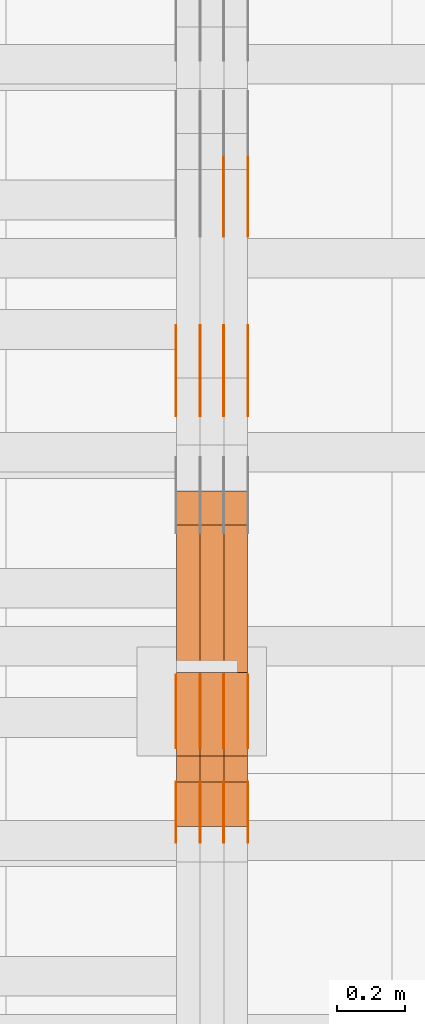
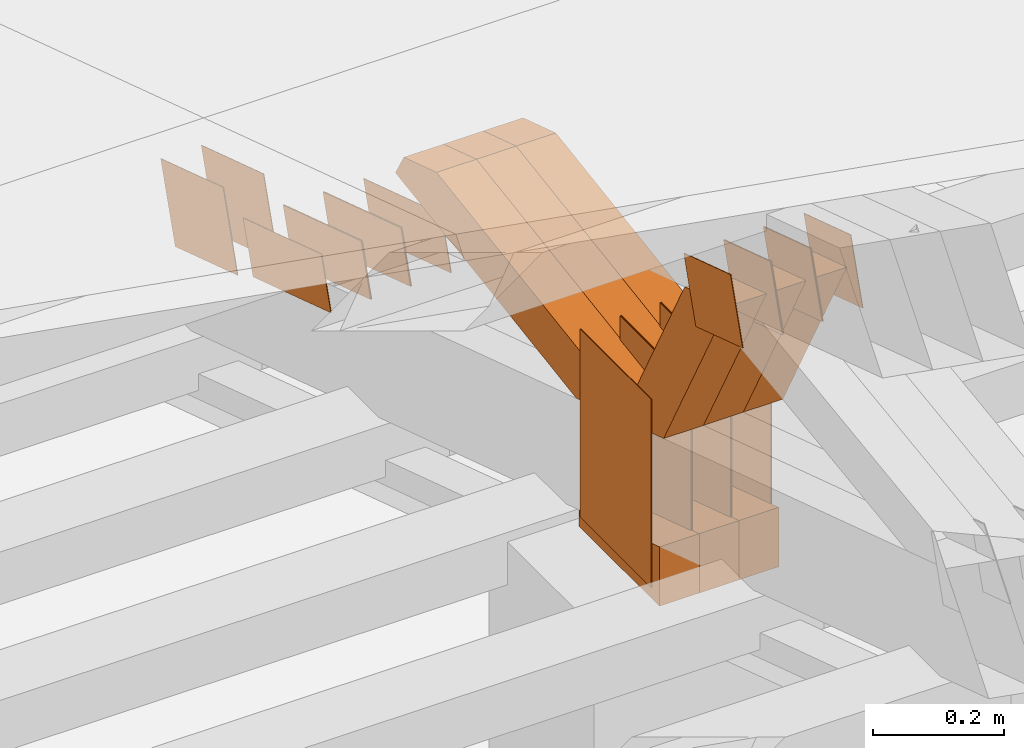
# One storey, part 86 of 385: 29 proxies.
"""IFC2X3 building model written with IfcOpenShell, lengths in millimetres."""

from ifc_helpers import new_model, entity, si_unit, converted_unit, derived_unit, direction, frame, origin, origin_2d_with_axis, place, context, subcontext, project, spatial, polyline, rectangle, outline, extrude, source, transform, mapped, material, type_object, type_shapes, element, save


model = new_model("IFC2X3")

# Units and contexts
model_context = context("Model", 3, precision=0.01, world=origin(), true_north=direction((6.12303176911189e-17, 1.0)))
body_context = subcontext(model_context, "Body", "Model", "MODEL_VIEW")
ifc_project = project(units=[si_unit("LENGTHUNIT", "METRE", prefix="MILLI"), si_unit("AREAUNIT", "SQUARE_METRE"), si_unit("VOLUMEUNIT", "CUBIC_METRE"), converted_unit("PLANEANGLEUNIT", "DEGREE", entity("IfcRatioMeasure", 0.0174532925199433), si_unit("PLANEANGLEUNIT", "RADIAN"), dimensions=[0, 0, 0, 0, 0, 0, 0]), si_unit("MASSUNIT", "GRAM", prefix="KILO"), derived_unit("MASSDENSITYUNIT", [(si_unit("MASSUNIT", "GRAM", prefix="KILO"), 1), (si_unit("LENGTHUNIT", "METRE"), -3)]), si_unit("TIMEUNIT", "SECOND"), si_unit("FREQUENCYUNIT", "HERTZ"), si_unit("THERMODYNAMICTEMPERATUREUNIT", "DEGREE_CELSIUS"), derived_unit("THERMALTRANSMITTANCEUNIT", [(si_unit("MASSUNIT", "GRAM", prefix="KILO"), 1), (si_unit("THERMODYNAMICTEMPERATUREUNIT", "KELVIN"), -1), (si_unit("TIMEUNIT", "SECOND"), -3)]), derived_unit("VOLUMETRICFLOWRATEUNIT", [(si_unit("LENGTHUNIT", "METRE"), 3), (si_unit("TIMEUNIT", "SECOND"), -1)]), si_unit("ELECTRICCURRENTUNIT", "AMPERE"), si_unit("ELECTRICVOLTAGEUNIT", "VOLT"), si_unit("POWERUNIT", "WATT"), si_unit("FORCEUNIT", "NEWTON", prefix="KILO"), si_unit("ILLUMINANCEUNIT", "LUX"), si_unit("LUMINOUSFLUXUNIT", "LUMEN"), si_unit("LUMINOUSINTENSITYUNIT", "CANDELA"), derived_unit("USERDEFINED", [(si_unit("MASSUNIT", "GRAM", prefix="KILO"), -1), (si_unit("LENGTHUNIT", "METRE"), -2), (si_unit("TIMEUNIT", "SECOND"), 3), (si_unit("LUMINOUSFLUXUNIT", "LUMEN"), 1)]), derived_unit("LINEARVELOCITYUNIT", [(si_unit("LENGTHUNIT", "METRE"), 1), (si_unit("TIMEUNIT", "SECOND"), -1)]), si_unit("PRESSUREUNIT", "PASCAL"), derived_unit("USERDEFINED", [(si_unit("LENGTHUNIT", "METRE"), -2), (si_unit("MASSUNIT", "GRAM", prefix="KILO"), 1), (si_unit("TIMEUNIT", "SECOND"), -2)])], contexts=[model_context])

# Site, building, storey
site_placement = place(None, origin())
site = spatial("IfcSite", under=ifc_project, at=site_placement, CompositionType="ELEMENT")
building_placement = place(site_placement, origin())
building = spatial("IfcBuilding", under=site, at=building_placement, CompositionType="ELEMENT")
storey_placement = place(building_placement, origin())
storey = spatial("IfcBuildingStorey", under=building, at=storey_placement, Name="Default", CompositionType="ELEMENT", Elevation=0.0)

# Proxies
ifc_material_1 = material(Name="IfcSurfaceStyle #66966")
building_element_proxy_type_1 = type_object("IfcBuildingElementProxyType", PredefinedType="NOTDEFINED", material=ifc_material_1)
shared_shape_1 = source(origin(), body_context, "Body", "SweptSolid", [
    extrude(outline(polyline([(-125.00031378339, -47.9999612158856), (125.000225258022, -47.9999612158856), (124.999811678525, 47.9999612158856), (-124.999723153156, 47.9999612158856), (-125.00031378339, -47.9999612158856)])), frame((125.000225258022, 48.0000091013474, 0.0), z_axis=(0.0, 0.0, 1.0), x_axis=(-1.0, 0.0, 0.0)), (0.0, 0.0, 1.0), 1.3),
])
type_shapes(building_element_proxy_type_1, [shared_shape_1])
proxy_1_placement = place(building_placement, frame((3386.29999999999, 18456.8597683375, 2657.46691321253), z_axis=(-1.0, 0.0, 0.0), x_axis=(0.0, -0.951056516295124, 0.309016994375039)))
element("IfcBuildingElementProxy", 1, at=proxy_1_placement, inside=storey, type_object=building_element_proxy_type_1, material=ifc_material_1, context=body_context, shape_type="MappedRepresentation", body=[
    mapped(shared_shape_1, transform((0.0, 0.0, 0.0), scale=1.0)),
])
ifc_material_2 = material(Name="IfcSurfaceStyle #66909")
building_element_proxy_type_2 = type_object("IfcBuildingElementProxyType", PredefinedType="NOTDEFINED", material=ifc_material_2)
shared_shape_2 = source(origin(), body_context, "Body", "SweptSolid", [
    extrude(outline(polyline([(-125.00031378339, -47.9999612158856), (125.000225258022, -47.9999612158856), (124.999811678525, 47.9999612158856), (-124.999723153156, 47.9999612158856), (-125.00031378339, -47.9999612158856)])), frame((125.000225258022, 48.0000091013474, 0.0), z_axis=(0.0, 0.0, 1.0), x_axis=(-1.0, 0.0, 0.0)), (0.0, 0.0, 1.0), 1.3),
])
type_shapes(building_element_proxy_type_2, [shared_shape_2])
proxy_2_placement = place(building_placement, frame((3315.0, 18456.8597683375, 2657.46691321253), z_axis=(-1.0, 0.0, 0.0), x_axis=(0.0, -0.951056516295124, 0.309016994375039)))
element("IfcBuildingElementProxy", 2, at=proxy_2_placement, inside=storey, type_object=building_element_proxy_type_2, material=ifc_material_2, context=body_context, shape_type="MappedRepresentation", body=[
    mapped(shared_shape_2, transform((0.0, 0.0, 0.0), scale=1.0)),
])
ifc_material_3 = material(Name="IfcSurfaceStyle #66852")
building_element_proxy_type_3 = type_object("IfcBuildingElementProxyType", PredefinedType="NOTDEFINED", material=ifc_material_3)
shared_shape_3 = source(origin(), body_context, "Body", "SweptSolid", [
    extrude(outline(polyline([(-125.00031378339, -47.9999612158856), (125.000225258022, -47.9999612158856), (124.999811678525, 47.9999612158856), (-124.999723153156, 47.9999612158856), (-125.00031378339, -47.9999612158856)])), frame((125.000225258022, 48.0000091013474, 0.0), z_axis=(0.0, 0.0, 1.0), x_axis=(-1.0, 0.0, 0.0)), (0.0, 0.0, 1.0), 1.3),
])
type_shapes(building_element_proxy_type_3, [shared_shape_3])
proxy_3_placement = place(building_placement, frame((3316.29999999999, 18456.8597683375, 2657.46691321253), z_axis=(-1.0, 0.0, 0.0), x_axis=(0.0, -0.951056516295124, 0.309016994375039)))
element("IfcBuildingElementProxy", 3, at=proxy_3_placement, inside=storey, type_object=building_element_proxy_type_3, material=ifc_material_3, context=body_context, shape_type="MappedRepresentation", body=[
    mapped(shared_shape_3, transform((0.0, 0.0, 0.0), scale=1.0)),
])
ifc_material_4 = material(Name="IfcSurfaceStyle #66795")
building_element_proxy_type_4 = type_object("IfcBuildingElementProxyType", PredefinedType="NOTDEFINED", material=ifc_material_4)
shared_shape_4 = source(origin(), body_context, "Body", "SweptSolid", [
    extrude(outline(polyline([(-125.00031378339, -47.9999612158856), (125.000225258022, -47.9999612158856), (124.999811678525, 47.9999612158856), (-124.999723153156, 47.9999612158856), (-125.00031378339, -47.9999612158856)])), frame((125.000225258022, 48.0000091013474, 0.0), z_axis=(0.0, 0.0, 1.0), x_axis=(-1.0, 0.0, 0.0)), (0.0, 0.0, 1.0), 1.29999999999998),
])
type_shapes(building_element_proxy_type_4, [shared_shape_4])
proxy_4_placement = place(building_placement, frame((3245.0, 18456.8597683375, 2657.46691321253), z_axis=(-1.0, 0.0, 0.0), x_axis=(0.0, -0.951056516295124, 0.309016994375039)))
element("IfcBuildingElementProxy", 4, at=proxy_4_placement, inside=storey, type_object=building_element_proxy_type_4, material=ifc_material_4, context=body_context, shape_type="MappedRepresentation", body=[
    mapped(shared_shape_4, transform((0.0, 0.0, 0.0), scale=1.0)),
])
ifc_material_5 = material(Name="IfcSurfaceStyle #66738")
building_element_proxy_type_5 = type_object("IfcBuildingElementProxyType", PredefinedType="NOTDEFINED", material=ifc_material_5)
shared_shape_5 = source(origin(), body_context, "Body", "SweptSolid", [
    extrude(outline(polyline([(-125.00031378339, -47.9999612158856), (125.000225258022, -47.9999612158856), (124.999811678525, 47.9999612158856), (-124.999723153156, 47.9999612158856), (-125.00031378339, -47.9999612158856)])), frame((125.000225258022, 48.0000091013474, 0.0), z_axis=(0.0, 0.0, 1.0), x_axis=(-1.0, 0.0, 0.0)), (0.0, 0.0, 1.0), 1.29999999999998),
])
type_shapes(building_element_proxy_type_5, [shared_shape_5])
proxy_5_placement = place(building_placement, frame((3246.29999999999, 18456.8597683375, 2657.46691321253), z_axis=(-1.0, 0.0, 0.0), x_axis=(0.0, -0.951056516295124, 0.309016994375039)))
element("IfcBuildingElementProxy", 5, at=proxy_5_placement, inside=storey, type_object=building_element_proxy_type_5, material=ifc_material_5, context=body_context, shape_type="MappedRepresentation", body=[
    mapped(shared_shape_5, transform((0.0, 0.0, 0.0), scale=1.0)),
])
ifc_material_6 = material(Name="IfcSurfaceStyle #66681")
building_element_proxy_type_6 = type_object("IfcBuildingElementProxyType", PredefinedType="NOTDEFINED", material=ifc_material_6)
shared_shape_6 = source(origin(), body_context, "Body", "SweptSolid", [
    extrude(outline(polyline([(-125.00031378339, -47.9999612158856), (125.000225258022, -47.9999612158856), (124.999811678525, 47.9999612158856), (-124.999723153156, 47.9999612158856), (-125.00031378339, -47.9999612158856)])), frame((125.000225258022, 48.0000091013474, 0.0), z_axis=(0.0, 0.0, 1.0), x_axis=(-1.0, 0.0, 0.0)), (0.0, 0.0, 1.0), 1.29999999999998),
])
type_shapes(building_element_proxy_type_6, [shared_shape_6])
proxy_6_placement = place(building_placement, frame((3175.0, 18456.8597683375, 2657.46691321253), z_axis=(-1.0, 0.0, 0.0), x_axis=(0.0, -0.951056516295124, 0.309016994375039)))
element("IfcBuildingElementProxy", 6, at=proxy_6_placement, inside=storey, type_object=building_element_proxy_type_6, material=ifc_material_6, context=body_context, shape_type="MappedRepresentation", body=[
    mapped(shared_shape_6, transform((0.0, 0.0, 0.0), scale=1.0)),
])
ifc_material_7 = material(Name="IfcSurfaceStyle #65256")
building_element_proxy_type_7 = type_object("IfcBuildingElementProxyType", PredefinedType="NOTDEFINED", material=ifc_material_7)
shared_shape_7 = source(origin(), body_context, "Body", "SweptSolid", [
    extrude(outline(polyline([(-99.999796294464, -72.0000050220467), (99.9998768370438, -72.0000050220467), (100.000260677528, 72.0000050220467), (-100.000341220108, 72.0000050220467), (-99.999796294464, -72.0000050220467)])), frame((100.000260677528, 72.0000050220467, 0.0), z_axis=(0.0, 0.0, 1.0), x_axis=(-1.0, 0.0, 0.0)), (0.0, 0.0, 1.0), 1.3),
])
type_shapes(building_element_proxy_type_7, [shared_shape_7])
proxy_7_placement = place(building_placement, frame((3386.29999999999, 18936.3876569477, 2373.90613192527), z_axis=(-1.0, 0.0, 0.0), x_axis=(0.0, -0.951056516295124, 0.309016994375039)))
element("IfcBuildingElementProxy", 7, at=proxy_7_placement, inside=storey, type_object=building_element_proxy_type_7, material=ifc_material_7, context=body_context, shape_type="MappedRepresentation", body=[
    mapped(shared_shape_7, transform((0.0, 0.0, 0.0), scale=1.0)),
])
ifc_material_8 = material(Name="IfcSurfaceStyle #65199")
building_element_proxy_type_8 = type_object("IfcBuildingElementProxyType", PredefinedType="NOTDEFINED", material=ifc_material_8)
shared_shape_8 = source(origin(), body_context, "Body", "SweptSolid", [
    extrude(outline(polyline([(-99.999796294464, -72.0000050220467), (99.9998768370438, -72.0000050220467), (100.000260677528, 72.0000050220467), (-100.000341220108, 72.0000050220467), (-99.999796294464, -72.0000050220467)])), frame((100.000260677528, 72.0000050220467, 0.0), z_axis=(0.0, 0.0, 1.0), x_axis=(-1.0, 0.0, 0.0)), (0.0, 0.0, 1.0), 1.3),
])
type_shapes(building_element_proxy_type_8, [shared_shape_8])
proxy_8_placement = place(building_placement, frame((3315.0, 18936.3876569477, 2373.90613192527), z_axis=(-1.0, 0.0, 0.0), x_axis=(0.0, -0.951056516295124, 0.309016994375039)))
element("IfcBuildingElementProxy", 8, at=proxy_8_placement, inside=storey, type_object=building_element_proxy_type_8, material=ifc_material_8, context=body_context, shape_type="MappedRepresentation", body=[
    mapped(shared_shape_8, transform((0.0, 0.0, 0.0), scale=1.0)),
])
ifc_material_9 = material(Name="IfcSurfaceStyle #64914")
building_element_proxy_type_9 = type_object("IfcBuildingElementProxyType", PredefinedType="NOTDEFINED", material=ifc_material_9)
shared_shape_9 = source(origin(), body_context, "Body", "SweptSolid", [
    extrude(rectangle(XDim=350.0, YDim=215.999999999984, at=origin_2d_with_axis()), frame((175.0, 108.0, 0.0), z_axis=(0.0, 0.0, 1.0), x_axis=(-1.0, 0.0, 0.0)), (0.0, 0.0, 1.0), 1.29999999999999),
])
type_shapes(building_element_proxy_type_9, [shared_shape_9])
proxy_9_placement = place(building_placement, frame((3386.29999999999, 17459.2939453125, 3165.36425781251), z_axis=(-1.0, 0.0, 0.0), x_axis=(0.0, 0.0, -1.0)))
element("IfcBuildingElementProxy", 9, at=proxy_9_placement, inside=storey, type_object=building_element_proxy_type_9, material=ifc_material_9, context=body_context, shape_type="MappedRepresentation", body=[
    mapped(shared_shape_9, transform((0.0, 0.0, 0.0), scale=1.0)),
])
ifc_material_10 = material(Name="IfcSurfaceStyle #64857")
building_element_proxy_type_10 = type_object("IfcBuildingElementProxyType", PredefinedType="NOTDEFINED", material=ifc_material_10)
shared_shape_10 = source(origin(), body_context, "Body", "SweptSolid", [
    extrude(rectangle(XDim=350.0, YDim=215.999999999984, at=origin_2d_with_axis()), frame((175.0, 108.0, 0.0), z_axis=(0.0, 0.0, 1.0), x_axis=(-1.0, 0.0, 0.0)), (0.0, 0.0, 1.0), 1.29999999999999),
])
type_shapes(building_element_proxy_type_10, [shared_shape_10])
proxy_10_placement = place(building_placement, frame((3315.0, 17459.2939453125, 3165.36425781251), z_axis=(-1.0, 0.0, 0.0), x_axis=(0.0, 0.0, -1.0)))
element("IfcBuildingElementProxy", 10, at=proxy_10_placement, inside=storey, type_object=building_element_proxy_type_10, material=ifc_material_10, context=body_context, shape_type="MappedRepresentation", body=[
    mapped(shared_shape_10, transform((0.0, 0.0, 0.0), scale=1.0)),
])
ifc_material_11 = material(Name="IfcSurfaceStyle #64800")
building_element_proxy_type_11 = type_object("IfcBuildingElementProxyType", PredefinedType="NOTDEFINED", material=ifc_material_11)
shared_shape_11 = source(origin(), body_context, "Body", "SweptSolid", [
    extrude(rectangle(XDim=350.0, YDim=215.999999999984, at=origin_2d_with_axis()), frame((175.0, 108.0, 0.0), z_axis=(0.0, 0.0, 1.0), x_axis=(-1.0, 0.0, 0.0)), (0.0, 0.0, 1.0), 1.29999999999999),
])
type_shapes(building_element_proxy_type_11, [shared_shape_11])
proxy_11_placement = place(building_placement, frame((3316.29999999999, 17459.2939453125, 3165.36425781251), z_axis=(-1.0, 0.0, 0.0), x_axis=(0.0, 0.0, -1.0)))
element("IfcBuildingElementProxy", 11, at=proxy_11_placement, inside=storey, type_object=building_element_proxy_type_11, material=ifc_material_11, context=body_context, shape_type="MappedRepresentation", body=[
    mapped(shared_shape_11, transform((0.0, 0.0, 0.0), scale=1.0)),
])
ifc_material_12 = material(Name="IfcSurfaceStyle #64743")
building_element_proxy_type_12 = type_object("IfcBuildingElementProxyType", PredefinedType="NOTDEFINED", material=ifc_material_12)
shared_shape_12 = source(origin(), body_context, "Body", "SweptSolid", [
    extrude(rectangle(XDim=350.0, YDim=215.999999999984, at=origin_2d_with_axis()), frame((175.0, 108.0, 0.0), z_axis=(0.0, 0.0, 1.0), x_axis=(-1.0, 0.0, 0.0)), (0.0, 0.0, 1.0), 1.29999999999998),
])
type_shapes(building_element_proxy_type_12, [shared_shape_12])
proxy_12_placement = place(building_placement, frame((3245.0, 17459.2939453125, 3165.36425781251), z_axis=(-1.0, 0.0, 0.0), x_axis=(0.0, 0.0, -1.0)))
element("IfcBuildingElementProxy", 12, at=proxy_12_placement, inside=storey, type_object=building_element_proxy_type_12, material=ifc_material_12, context=body_context, shape_type="MappedRepresentation", body=[
    mapped(shared_shape_12, transform((0.0, 0.0, 0.0), scale=1.0)),
])
ifc_material_13 = material(Name="IfcSurfaceStyle #64686")
building_element_proxy_type_13 = type_object("IfcBuildingElementProxyType", PredefinedType="NOTDEFINED", material=ifc_material_13)
shared_shape_13 = source(origin(), body_context, "Body", "SweptSolid", [
    extrude(rectangle(XDim=350.0, YDim=215.999999999984, at=origin_2d_with_axis()), frame((175.0, 108.0, 0.0), z_axis=(0.0, 0.0, 1.0), x_axis=(-1.0, 0.0, 0.0)), (0.0, 0.0, 1.0), 1.29999999999998),
])
type_shapes(building_element_proxy_type_13, [shared_shape_13])
proxy_13_placement = place(building_placement, frame((3246.29999999999, 17459.2939453125, 3165.36425781251), z_axis=(-1.0, 0.0, 0.0), x_axis=(0.0, 0.0, -1.0)))
element("IfcBuildingElementProxy", 13, at=proxy_13_placement, inside=storey, type_object=building_element_proxy_type_13, material=ifc_material_13, context=body_context, shape_type="MappedRepresentation", body=[
    mapped(shared_shape_13, transform((0.0, 0.0, 0.0), scale=1.0)),
])
ifc_material_14 = material(Name="IfcSurfaceStyle #64629")
building_element_proxy_type_14 = type_object("IfcBuildingElementProxyType", PredefinedType="NOTDEFINED", material=ifc_material_14)
shared_shape_14 = source(origin(), body_context, "Body", "SweptSolid", [
    extrude(rectangle(XDim=350.0, YDim=215.999999999984, at=origin_2d_with_axis()), frame((175.0, 108.0, 0.0), z_axis=(0.0, 0.0, 1.0), x_axis=(-1.0, 0.0, 0.0)), (0.0, 0.0, 1.0), 1.29999999999998),
])
type_shapes(building_element_proxy_type_14, [shared_shape_14])
proxy_14_placement = place(building_placement, frame((3175.0, 17459.2939453125, 3165.36425781251), z_axis=(-1.0, 0.0, 0.0), x_axis=(0.0, 0.0, -1.0)))
element("IfcBuildingElementProxy", 14, at=proxy_14_placement, inside=storey, type_object=building_element_proxy_type_14, material=ifc_material_14, context=body_context, shape_type="MappedRepresentation", body=[
    mapped(shared_shape_14, transform((0.0, 0.0, 0.0), scale=1.0)),
])
ifc_material_15 = material(Name="IfcSurfaceStyle #61494")
building_element_proxy_type_15 = type_object("IfcBuildingElementProxyType", PredefinedType="NOTDEFINED", material=ifc_material_15)
shared_shape_15 = source(origin(), body_context, "Body", "SweptSolid", [
    extrude(outline(polyline([(-74.9998605591058, -59.9999264677524), (74.999875428623, -59.9999264677524), (74.9998605591068, 59.9999264677524), (-74.9998754286239, 59.9999264677524), (-74.9998605591058, -59.9999264677524)])), frame((75.0002460484325, 60.0000016373508, 0.0), z_axis=(0.0, 0.0, 1.0), x_axis=(-1.0, 0.0, 0.0)), (0.0, 0.0, 1.0), 1.3),
])
type_shapes(building_element_proxy_type_15, [shared_shape_15])
proxy_15_placement = place(building_placement, frame((3386.29999999999, 17107.0599369346, 3383.82825001787), z_axis=(-1.0, 0.0, 0.0), x_axis=(0.0, -0.951056516295154, 0.309016994374948)))
element("IfcBuildingElementProxy", 15, at=proxy_15_placement, inside=storey, type_object=building_element_proxy_type_15, material=ifc_material_15, context=body_context, shape_type="MappedRepresentation", body=[
    mapped(shared_shape_15, transform((0.0, 0.0, 0.0), scale=1.0)),
])
ifc_material_16 = material(Name="IfcSurfaceStyle #61437")
building_element_proxy_type_16 = type_object("IfcBuildingElementProxyType", PredefinedType="NOTDEFINED", material=ifc_material_16)
shared_shape_16 = source(origin(), body_context, "Body", "SweptSolid", [
    extrude(outline(polyline([(-74.9998605591058, -59.9999264677524), (74.999875428623, -59.9999264677524), (74.9998605591068, 59.9999264677524), (-74.9998754286239, 59.9999264677524), (-74.9998605591058, -59.9999264677524)])), frame((75.0002460484325, 60.0000016373508, 0.0), z_axis=(0.0, 0.0, 1.0), x_axis=(-1.0, 0.0, 0.0)), (0.0, 0.0, 1.0), 1.3),
])
type_shapes(building_element_proxy_type_16, [shared_shape_16])
proxy_16_placement = place(building_placement, frame((3315.0, 17107.0599369346, 3383.82825001787), z_axis=(-1.0, 0.0, 0.0), x_axis=(0.0, -0.951056516295154, 0.309016994374948)))
element("IfcBuildingElementProxy", 16, at=proxy_16_placement, inside=storey, type_object=building_element_proxy_type_16, material=ifc_material_16, context=body_context, shape_type="MappedRepresentation", body=[
    mapped(shared_shape_16, transform((0.0, 0.0, 0.0), scale=1.0)),
])
ifc_material_17 = material(Name="IfcSurfaceStyle #61380")
building_element_proxy_type_17 = type_object("IfcBuildingElementProxyType", PredefinedType="NOTDEFINED", material=ifc_material_17)
shared_shape_17 = source(origin(), body_context, "Body", "SweptSolid", [
    extrude(outline(polyline([(-74.9998605591058, -59.9999264677524), (74.999875428623, -59.9999264677524), (74.9998605591068, 59.9999264677524), (-74.9998754286239, 59.9999264677524), (-74.9998605591058, -59.9999264677524)])), frame((75.0002460484325, 60.0000016373508, 0.0), z_axis=(0.0, 0.0, 1.0), x_axis=(-1.0, 0.0, 0.0)), (0.0, 0.0, 1.0), 1.3),
])
type_shapes(building_element_proxy_type_17, [shared_shape_17])
proxy_17_placement = place(building_placement, frame((3316.29999999999, 17107.0599369346, 3383.82825001787), z_axis=(-1.0, 0.0, 0.0), x_axis=(0.0, -0.951056516295154, 0.309016994374948)))
element("IfcBuildingElementProxy", 17, at=proxy_17_placement, inside=storey, type_object=building_element_proxy_type_17, material=ifc_material_17, context=body_context, shape_type="MappedRepresentation", body=[
    mapped(shared_shape_17, transform((0.0, 0.0, 0.0), scale=1.0)),
])
ifc_material_18 = material(Name="IfcSurfaceStyle #61323")
building_element_proxy_type_18 = type_object("IfcBuildingElementProxyType", PredefinedType="NOTDEFINED", material=ifc_material_18)
shared_shape_18 = source(origin(), body_context, "Body", "SweptSolid", [
    extrude(outline(polyline([(-74.9998605591058, -59.9999264677524), (74.999875428623, -59.9999264677524), (74.9998605591068, 59.9999264677524), (-74.9998754286239, 59.9999264677524), (-74.9998605591058, -59.9999264677524)])), frame((75.0002460484325, 60.0000016373508, 0.0), z_axis=(0.0, 0.0, 1.0), x_axis=(-1.0, 0.0, 0.0)), (0.0, 0.0, 1.0), 1.29999999999999),
])
type_shapes(building_element_proxy_type_18, [shared_shape_18])
proxy_18_placement = place(building_placement, frame((3245.0, 17107.0599369346, 3383.82825001787), z_axis=(-1.0, 0.0, 0.0), x_axis=(0.0, -0.951056516295154, 0.309016994374948)))
element("IfcBuildingElementProxy", 18, at=proxy_18_placement, inside=storey, type_object=building_element_proxy_type_18, material=ifc_material_18, context=body_context, shape_type="MappedRepresentation", body=[
    mapped(shared_shape_18, transform((0.0, 0.0, 0.0), scale=1.0)),
])
ifc_material_19 = material(Name="IfcSurfaceStyle #61266")
building_element_proxy_type_19 = type_object("IfcBuildingElementProxyType", PredefinedType="NOTDEFINED", material=ifc_material_19)
shared_shape_19 = source(origin(), body_context, "Body", "SweptSolid", [
    extrude(outline(polyline([(-74.9998605591058, -59.9999264677524), (74.999875428623, -59.9999264677524), (74.9998605591068, 59.9999264677524), (-74.9998754286239, 59.9999264677524), (-74.9998605591058, -59.9999264677524)])), frame((75.0002460484325, 60.0000016373508, 0.0), z_axis=(0.0, 0.0, 1.0), x_axis=(-1.0, 0.0, 0.0)), (0.0, 0.0, 1.0), 1.29999999999999),
])
type_shapes(building_element_proxy_type_19, [shared_shape_19])
proxy_19_placement = place(building_placement, frame((3246.29999999999, 17107.0599369346, 3383.82825001787), z_axis=(-1.0, 0.0, 0.0), x_axis=(0.0, -0.951056516295154, 0.309016994374948)))
element("IfcBuildingElementProxy", 19, at=proxy_19_placement, inside=storey, type_object=building_element_proxy_type_19, material=ifc_material_19, context=body_context, shape_type="MappedRepresentation", body=[
    mapped(shared_shape_19, transform((0.0, 0.0, 0.0), scale=1.0)),
])
ifc_material_20 = material(Name="IfcSurfaceStyle #61209")
building_element_proxy_type_20 = type_object("IfcBuildingElementProxyType", PredefinedType="NOTDEFINED", material=ifc_material_20)
shared_shape_20 = source(origin(), body_context, "Body", "SweptSolid", [
    extrude(outline(polyline([(-74.9998605591058, -59.9999264677524), (74.999875428623, -59.9999264677524), (74.9998605591068, 59.9999264677524), (-74.9998754286239, 59.9999264677524), (-74.9998605591058, -59.9999264677524)])), frame((75.0002460484325, 60.0000016373508, 0.0), z_axis=(0.0, 0.0, 1.0), x_axis=(-1.0, 0.0, 0.0)), (0.0, 0.0, 1.0), 1.29999999999999),
])
type_shapes(building_element_proxy_type_20, [shared_shape_20])
proxy_20_placement = place(building_placement, frame((3175.0, 17107.0599369346, 3383.82825001787), z_axis=(-1.0, 0.0, 0.0), x_axis=(0.0, -0.951056516295154, 0.309016994374948)))
element("IfcBuildingElementProxy", 20, at=proxy_20_placement, inside=storey, type_object=building_element_proxy_type_20, material=ifc_material_20, context=body_context, shape_type="MappedRepresentation", body=[
    mapped(shared_shape_20, transform((0.0, 0.0, 0.0), scale=1.0)),
])
ifc_material_21 = material(Name="IfcSurfaceStyle #53205")
building_element_proxy_type_21 = type_object("IfcBuildingElementProxyType", Name="T1-E1 53203", PredefinedType="NOTDEFINED", material=ifc_material_21)
shared_shape_21 = source(origin(), body_context, "Body", "SweptSolid", [
    extrude(outline(polyline([(4.4675903320374, -122.500000000001), (35.3350219726624, -122.500000000001), (35.3350219726501, 122.500000000001), (-75.1376342773499, 122.500000000001), (4.4675903320374, -122.500000000001)])), frame((35.3350219726624, 122.50000005215, 0.0), z_axis=(0.0, 0.0, 1.0), x_axis=(-1.0, 0.0, 0.0)), (0.0, 0.0, 1.0), 70.0),
])
type_shapes(building_element_proxy_type_21, [shared_shape_21])
proxy_21_placement = place(building_placement, frame((3385.0, 17220.0, 2794.30932617186), z_axis=(-1.0, 0.0, 0.0), x_axis=(0.0, 0.0, 1.0)))
element("IfcBuildingElementProxy", 21, at=proxy_21_placement, inside=storey, type_object=building_element_proxy_type_21, material=ifc_material_21, Name="T1-E1", context=body_context, shape_type="MappedRepresentation", body=[
    mapped(shared_shape_21, transform((0.0, 0.0, 0.0), scale=1.0)),
])
ifc_material_22 = material(Name="IfcSurfaceStyle #53148")
building_element_proxy_type_22 = type_object("IfcBuildingElementProxyType", Name="T1-E1 53146", PredefinedType="NOTDEFINED", material=ifc_material_22)
shared_shape_22 = source(origin(), body_context, "Body", "SweptSolid", [
    extrude(outline(polyline([(4.4675903320374, -122.500000000001), (35.3350219726624, -122.500000000001), (35.3350219726501, 122.500000000001), (-75.1376342773499, 122.500000000001), (4.4675903320374, -122.500000000001)])), frame((35.3350219726624, 122.50000005215, 0.0), z_axis=(0.0, 0.0, 1.0), x_axis=(-1.0, 0.0, 0.0)), (0.0, 0.0, 1.0), 70.0),
])
type_shapes(building_element_proxy_type_22, [shared_shape_22])
proxy_22_placement = place(building_placement, frame((3315.0, 17220.0, 2794.30932617186), z_axis=(-1.0, 0.0, 0.0), x_axis=(0.0, 0.0, 1.0)))
element("IfcBuildingElementProxy", 22, at=proxy_22_placement, inside=storey, type_object=building_element_proxy_type_22, material=ifc_material_22, Name="T1-E1", context=body_context, shape_type="MappedRepresentation", body=[
    mapped(shared_shape_22, transform((0.0, 0.0, 0.0), scale=1.0)),
])
ifc_material_23 = material(Name="IfcSurfaceStyle #53091")
building_element_proxy_type_23 = type_object("IfcBuildingElementProxyType", Name="T1-E1 53089", PredefinedType="NOTDEFINED", material=ifc_material_23)
shared_shape_23 = source(origin(), body_context, "Body", "SweptSolid", [
    extrude(outline(polyline([(4.4675903320374, -122.500000000001), (35.3350219726624, -122.500000000001), (35.3350219726501, 122.500000000001), (-75.1376342773499, 122.500000000001), (4.4675903320374, -122.500000000001)])), frame((35.3350219726624, 122.50000005215, 0.0), z_axis=(0.0, 0.0, 1.0), x_axis=(-1.0, 0.0, 0.0)), (0.0, 0.0, 1.0), 70.0),
])
type_shapes(building_element_proxy_type_23, [shared_shape_23])
proxy_23_placement = place(building_placement, frame((3245.0, 17220.0, 2794.30932617186), z_axis=(-1.0, 0.0, 0.0), x_axis=(0.0, 0.0, 1.0)))
element("IfcBuildingElementProxy", 23, at=proxy_23_placement, inside=storey, type_object=building_element_proxy_type_23, material=ifc_material_23, Name="T1-E1", context=body_context, shape_type="MappedRepresentation", body=[
    mapped(shared_shape_23, transform((0.0, 0.0, 0.0), scale=1.0)),
])
ifc_material_24 = material(Name="IfcSurfaceStyle #51450")
building_element_proxy_type_24 = type_object("IfcBuildingElementProxyType", Name="T1-W39 51448", PredefinedType="NOTDEFINED", material=ifc_material_24)
shared_shape_24 = source(origin(), body_context, "Body", "SweptSolid", [
    extrude(outline(polyline([(-191.519946663886, -47.499928106579), (188.32936223763, -47.499928106579), (171.597440144109, 0.000249483340993841), (122.102882529753, 47.4998033649085), (-290.509738247605, 47.4998033649085), (-191.519946663886, -47.499928106579)])), frame((188.329593252001, 47.499957247623, 0.0), z_axis=(0.0, 0.0, 1.0), x_axis=(-1.0, 0.0, 0.0)), (0.0, 0.0, 1.0), 70.0),
])
type_shapes(building_element_proxy_type_24, [shared_shape_24])
proxy_24_placement = place(building_placement, frame((3385.0, 17238.5876916597, 3055.56121424762), z_axis=(-1.0, 0.0, 0.0), x_axis=(0.0, -0.472216932390777, 0.881482370080902)))
element("IfcBuildingElementProxy", 24, at=proxy_24_placement, inside=storey, type_object=building_element_proxy_type_24, material=ifc_material_24, Name="T1-W39", context=body_context, shape_type="MappedRepresentation", body=[
    mapped(shared_shape_24, transform((0.0, 0.0, 0.0), scale=1.0)),
])
ifc_material_25 = material(Name="IfcSurfaceStyle #51384")
building_element_proxy_type_25 = type_object("IfcBuildingElementProxyType", Name="T1-W39 51382", PredefinedType="NOTDEFINED", material=ifc_material_25)
shared_shape_25 = source(origin(), body_context, "Body", "SweptSolid", [
    extrude(outline(polyline([(-191.519946663886, -47.499928106579), (188.32936223763, -47.499928106579), (171.597440144109, 0.000249483340993841), (122.102882529753, 47.4998033649085), (-290.509738247605, 47.4998033649085), (-191.519946663886, -47.499928106579)])), frame((188.329593252001, 47.499957247623, 0.0), z_axis=(0.0, 0.0, 1.0), x_axis=(-1.0, 0.0, 0.0)), (0.0, 0.0, 1.0), 70.0),
])
type_shapes(building_element_proxy_type_25, [shared_shape_25])
proxy_25_placement = place(building_placement, frame((3315.0, 17238.5876916597, 3055.56121424762), z_axis=(-1.0, 0.0, 0.0), x_axis=(0.0, -0.472216932390777, 0.881482370080902)))
element("IfcBuildingElementProxy", 25, at=proxy_25_placement, inside=storey, type_object=building_element_proxy_type_25, material=ifc_material_25, Name="T1-W39", context=body_context, shape_type="MappedRepresentation", body=[
    mapped(shared_shape_25, transform((0.0, 0.0, 0.0), scale=1.0)),
])
ifc_material_26 = material(Name="IfcSurfaceStyle #51318")
building_element_proxy_type_26 = type_object("IfcBuildingElementProxyType", Name="T1-W39 51316", PredefinedType="NOTDEFINED", material=ifc_material_26)
shared_shape_26 = source(origin(), body_context, "Body", "SweptSolid", [
    extrude(outline(polyline([(-191.519946663886, -47.499928106579), (188.32936223763, -47.499928106579), (171.597440144109, 0.000249483340993841), (122.102882529753, 47.4998033649085), (-290.509738247605, 47.4998033649085), (-191.519946663886, -47.499928106579)])), frame((188.329593252001, 47.499957247623, 0.0), z_axis=(0.0, 0.0, 1.0), x_axis=(-1.0, 0.0, 0.0)), (0.0, 0.0, 1.0), 70.0),
])
type_shapes(building_element_proxy_type_26, [shared_shape_26])
proxy_26_placement = place(building_placement, frame((3245.0, 17238.5876916597, 3055.56121424762), z_axis=(-1.0, 0.0, 0.0), x_axis=(0.0, -0.472216932390777, 0.881482370080902)))
element("IfcBuildingElementProxy", 26, at=proxy_26_placement, inside=storey, type_object=building_element_proxy_type_26, material=ifc_material_26, Name="T1-W39", context=body_context, shape_type="MappedRepresentation", body=[
    mapped(shared_shape_26, transform((0.0, 0.0, 0.0), scale=1.0)),
])
ifc_material_27 = material(Name="IfcSurfaceStyle #51054")
building_element_proxy_type_27 = type_object("IfcBuildingElementProxyType", Name="T1-W10 51052", PredefinedType="NOTDEFINED", material=ifc_material_27)
shared_shape_27 = source(origin(), body_context, "Body", "SweptSolid", [
    extrude(outline(polyline([(-459.546036710757, -47.5000436364511), (174.689450869018, -47.5000436364511), (268.831081103959, 0.00011114562912502), (287.286350706789, 47.4999880636365), (-271.260845969009, 47.4999880636366), (-459.546036710757, -47.5000436364511)])), frame((287.286768781132, 47.5001637448091, 0.0), z_axis=(0.0, 0.0, 1.0), x_axis=(-1.0, 0.0, 0.0)), (0.0, 0.0, 1.0), 70.0),
])
type_shapes(building_element_proxy_type_27, [shared_shape_27])
proxy_27_placement = place(building_placement, frame((3385.0, 18025.1410649788, 3112.76453857986), z_axis=(-1.0, 0.0, 0.0), x_axis=(0.0, -0.988299196256916, -0.152527698068035)))
element("IfcBuildingElementProxy", 27, at=proxy_27_placement, inside=storey, type_object=building_element_proxy_type_27, material=ifc_material_27, Name="T1-W10", context=body_context, shape_type="MappedRepresentation", body=[
    mapped(shared_shape_27, transform((0.0, 0.0, 0.0), scale=1.0)),
])
ifc_material_28 = material(Name="IfcSurfaceStyle #50988")
building_element_proxy_type_28 = type_object("IfcBuildingElementProxyType", Name="T1-W10 50986", PredefinedType="NOTDEFINED", material=ifc_material_28)
shared_shape_28 = source(origin(), body_context, "Body", "SweptSolid", [
    extrude(outline(polyline([(-459.546036710757, -47.5000436364511), (174.689450869018, -47.5000436364511), (268.831081103959, 0.00011114562912502), (287.286350706789, 47.4999880636365), (-271.260845969009, 47.4999880636366), (-459.546036710757, -47.5000436364511)])), frame((287.286768781132, 47.5001637448091, 0.0), z_axis=(0.0, 0.0, 1.0), x_axis=(-1.0, 0.0, 0.0)), (0.0, 0.0, 1.0), 70.0),
])
type_shapes(building_element_proxy_type_28, [shared_shape_28])
proxy_28_placement = place(building_placement, frame((3315.0, 18025.1410649788, 3112.76453857986), z_axis=(-1.0, 0.0, 0.0), x_axis=(0.0, -0.988299196256916, -0.152527698068035)))
element("IfcBuildingElementProxy", 28, at=proxy_28_placement, inside=storey, type_object=building_element_proxy_type_28, material=ifc_material_28, Name="T1-W10", context=body_context, shape_type="MappedRepresentation", body=[
    mapped(shared_shape_28, transform((0.0, 0.0, 0.0), scale=1.0)),
])
ifc_material_29 = material(Name="IfcSurfaceStyle #50922")
building_element_proxy_type_29 = type_object("IfcBuildingElementProxyType", Name="T1-W10 50920", PredefinedType="NOTDEFINED", material=ifc_material_29)
shared_shape_29 = source(origin(), body_context, "Body", "SweptSolid", [
    extrude(outline(polyline([(-459.546036710757, -47.5000436364511), (174.689450869018, -47.5000436364511), (268.831081103959, 0.00011114562912502), (287.286350706789, 47.4999880636365), (-271.260845969009, 47.4999880636366), (-459.546036710757, -47.5000436364511)])), frame((287.286768781132, 47.5001637448091, 0.0), z_axis=(0.0, 0.0, 1.0), x_axis=(-1.0, 0.0, 0.0)), (0.0, 0.0, 1.0), 70.0),
])
type_shapes(building_element_proxy_type_29, [shared_shape_29])
proxy_29_placement = place(building_placement, frame((3245.0, 18025.1410649788, 3112.76453857986), z_axis=(-1.0, 0.0, 0.0), x_axis=(0.0, -0.988299196256916, -0.152527698068035)))
element("IfcBuildingElementProxy", 29, at=proxy_29_placement, inside=storey, type_object=building_element_proxy_type_29, material=ifc_material_29, Name="T1-W10", context=body_context, shape_type="MappedRepresentation", body=[
    mapped(shared_shape_29, transform((0.0, 0.0, 0.0), scale=1.0)),
])

save(model, "model.ifc")
